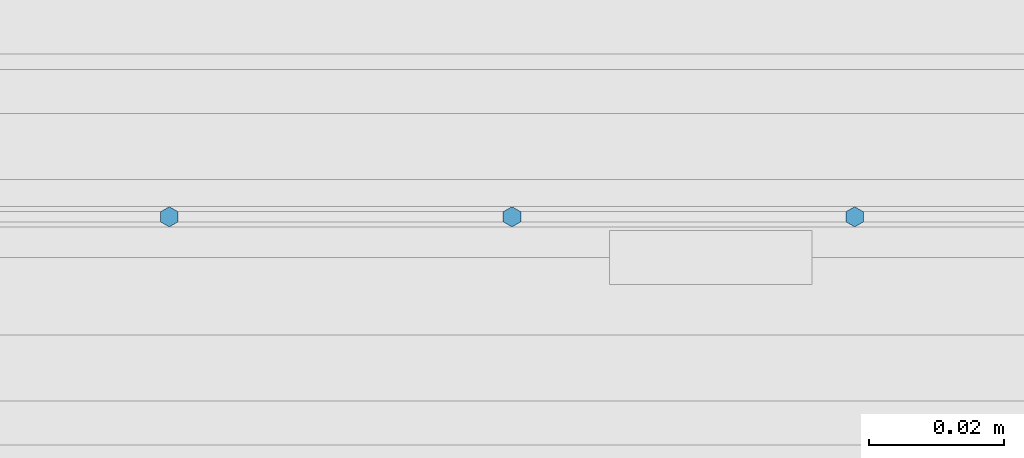
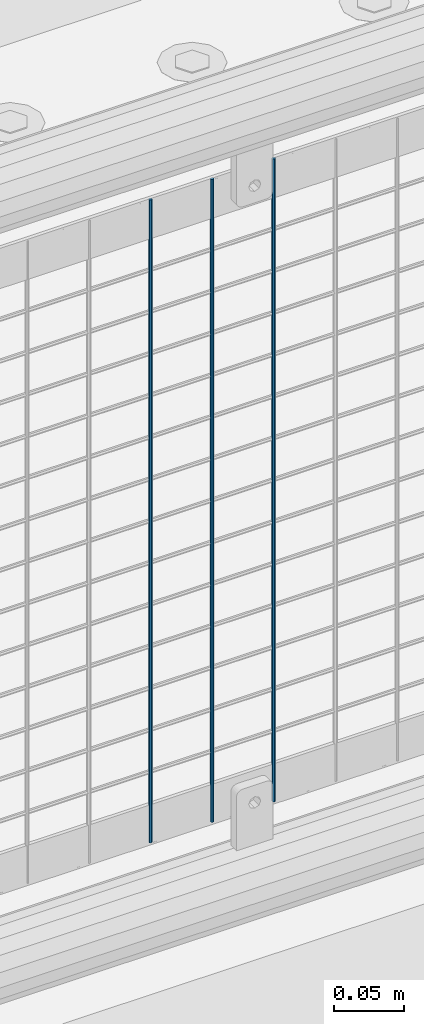
# One storey, part 69 of 270: 3 columns.
"""IFC2X3 building model written with IfcOpenShell, lengths in millimetres."""

from ifc_helpers import new_model, si_unit, frame, origin_with_axes, place, context, subcontext, project, spatial, faceted_brep, material, type_object, element, save


model = new_model("IFC2X3")

# Units and contexts
model_context = context("Model", 3, precision=1e-05, world=origin_with_axes())
body_context = subcontext(model_context, "Body", "Model", "MODEL_VIEW")
ifc_project = project(units=[si_unit("LENGTHUNIT", "METRE", prefix="MILLI"), si_unit("AREAUNIT", "SQUARE_METRE"), si_unit("VOLUMEUNIT", "CUBIC_METRE"), si_unit("MASSUNIT", "GRAM", prefix="KILO"), si_unit("TIMEUNIT", "SECOND"), si_unit("PLANEANGLEUNIT", "RADIAN"), si_unit("SOLIDANGLEUNIT", "STERADIAN"), si_unit("THERMODYNAMICTEMPERATUREUNIT", "DEGREE_CELSIUS"), si_unit("LUMINOUSINTENSITYUNIT", "LUMEN")], contexts=[model_context])

# Site, building, storey
site_placement = place(None, origin_with_axes())
site = spatial("IfcSite", under=ifc_project, at=site_placement, CompositionType="ELEMENT")
building_placement = place(site_placement, origin_with_axes())
building = spatial("IfcBuilding", under=site, at=building_placement, Name="Standard", CompositionType="ELEMENT")
storey_placement = place(building_placement, origin_with_axes())
storey = spatial("IfcBuildingStorey", under=building, at=storey_placement, Name="Undefined", CompositionType="ELEMENT", Elevation=0.0)

# Columns
ifc_material = material(Name="Misc_Undefined")
column_type = type_object("IfcColumnType", Name="D3", PredefinedType="NOTDEFINED")
for number, where, z_axis, x_axis in (
    (1, (1107.344, -16329.5, 353.02), (-1.0, 0.0, 0.0), (0.0, 0.0, 1.0)),
    (2, (1056.551, -16329.5, 353.02), (-1.0, 0.0, 0.0), (0.0, 0.0, 1.0)),
    (3, (1005.758, -16329.5, 353.02), (-1.0, 0.0, 0.0), (0.0, 0.0, 1.0)),
):
    element("IfcColumn", number, at=place(storey_placement, frame(where, z_axis=z_axis, x_axis=x_axis)), inside=storey, type_object=column_type, material=ifc_material, ObjectType="D3", context=body_context, shape_type="Brep", body=[
        faceted_brep([(0.0, -1.5, 0.0), (0.0, -0.75, -1.29903810567669), (560.0, -0.75, -1.29903810567703), (560.0, -1.5, 0.0), (0.0, 0.75, -1.29903810567669), (560.0, 0.75, -1.29903810567703), (0.0, 1.5, 0.0), (560.0, 1.5, 0.0), (0.0, 0.75, 1.29903810567669), (560.0, 0.75, 1.29903810567703), (0.0, -0.75, 1.29903810567669), (560.0, -0.75, 1.29903810567703)], [[[0, 1, 2, 3]], [[1, 4, 5, 2]], [[4, 6, 7, 5]], [[6, 8, 9, 7]], [[8, 10, 11, 9]], [[10, 0, 3, 11]], [[5, 7, 9, 11, 3, 2]], [[10, 8, 6, 4, 1, 0]]]),
    ])

save(model, "model.ifc")
